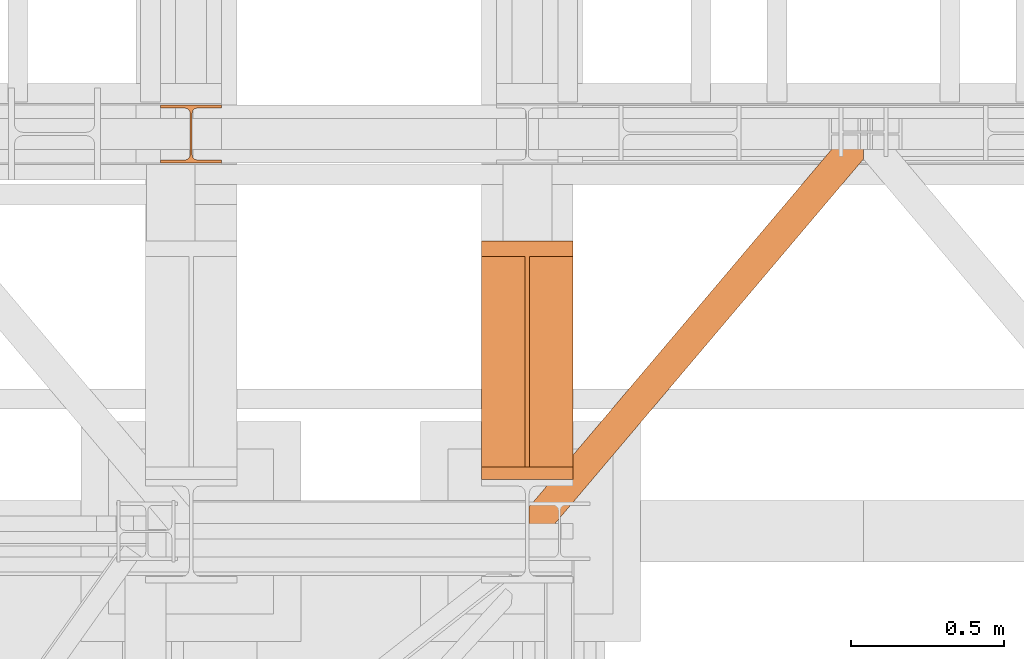
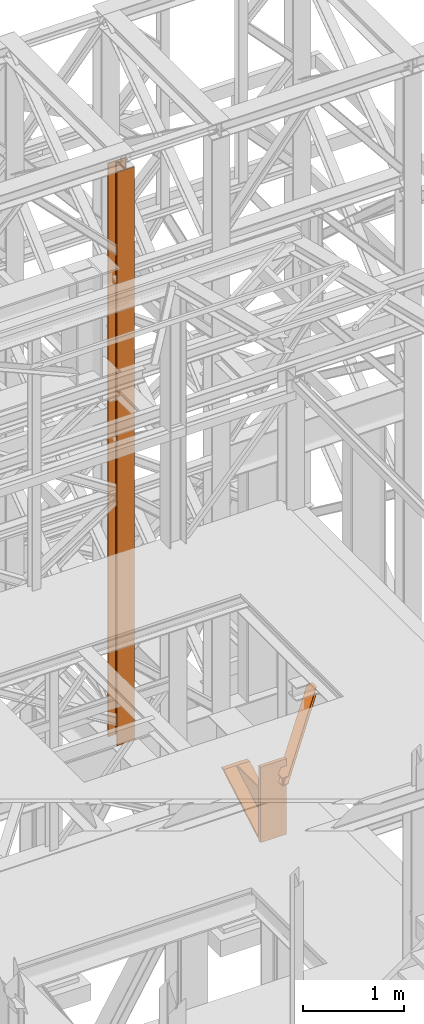
# One storey, part 151 of 208: 3 proxies.
"""IFC2X3 building model written with IfcOpenShell, lengths in millimetres."""

from ifc_helpers import new_model, entity, si_unit, converted_unit, frame, origin, origin_with_axes, place, context, subcontext, project, spatial, faceted_brep, element, save


model = new_model("IFC2X3")

# Units and contexts
model_context = context("Model", 3, precision=1e-05, world=origin())
plan_context = context("Plan", 3, precision=1e-05, world=origin())
body_context = subcontext(model_context, "Body", "Model", "MODEL_VIEW")
ifc_project = project(units=[si_unit("LENGTHUNIT", "METRE", prefix="MILLI"), converted_unit("PLANEANGLEUNIT", "DEGREE", entity("IfcPlaneAngleMeasure", 0.0174532925199433), si_unit("PLANEANGLEUNIT", "RADIAN"), dimensions=[0, 0, 0, 0, 0, 0, 0]), si_unit("AREAUNIT", "SQUARE_METRE"), si_unit("VOLUMEUNIT", "CUBIC_METRE")], contexts=[model_context, plan_context])

# Building, storey
building_placement = place(None, origin())
building = spatial("IfcBuilding", under=ifc_project, at=building_placement, CompositionType="COMPLEX")
storey_placement = place(building_placement, origin_with_axes())
storey = spatial("IfcBuildingStorey", under=building, at=storey_placement, Name="Geschoss", CompositionType="ELEMENT")

# Proxies
proxy_1_placement = place(storey_placement, frame((6443.254974489131, -17092.57439173937, 4367.230005364415), z_axis=(0.0, 0.0, 1.0), x_axis=(1.0, 0.0, 0.0)))
element("IfcBuildingElementProxy", 1, at=proxy_1_placement, inside=storey, context=body_context, shape_type="Brep", body=[
    faceted_brep([(0.01000000000021828, 40.0099999999984, 18.61000000000058), (300.0100000000002, 40.0099999999984, 18.61000000000058), (300.0100000000002, 779.8719999999976, 445.7700000000004), (0.01000000000021828, 779.8719999999976, 445.7700000000004), (0.01000000000021828, 779.8719999999976, 445.7700000000004), (300.0100000000002, 779.8719999999976, 445.7700000000004), (300.0100000000002, 729.8159999999989, 445.7710000000006), (157.5100000000002, 729.8159999999989, 445.7710000000006), (157.5100000000002, 40.0099999999984, 445.7700000000004), (142.5100000000002, 40.0099999999984, 445.7700000000004), (142.5100000000002, 729.8159999999989, 445.7710000000006), (0.01000000000021828, 729.8159999999971, 445.7710000000006), (0.01000000000021828, 729.8159999999971, 445.7710000000006), (142.5100000000002, 729.8159999999989, 445.7710000000006), (142.5100000000002, 40.0099999999984, 47.51000000000022), (0.01000000000021828, 40.0099999999984, 47.51000000000022), (157.5100000000002, 40.0099999999984, 47.51000000000022), (157.5100000000002, 729.8159999999989, 445.7710000000006), (300.0100000000002, 729.8159999999989, 445.7710000000006), (300.0100000000002, 40.0099999999984, 47.51000000000022), (0.01000000000021828, 40.0099999999984, 18.61000000000058), (0.01000000000021828, 779.8719999999976, 445.7700000000004), (0.01000000000021828, 729.8159999999971, 445.7710000000006), (0.01000000000021828, 40.0099999999984, 47.51000000000022), (0.01000000000021828, 40.0099999999984, 917.7700000000004), (0.01000000000021828, 0.00999999999839929, 917.7700000000004), (0.01000000000021828, 0.00999999999839929, 0.01000000000021828), (0.01000000000021828, 40.0099999999984, 0.01000000000021828), (300.0100000000002, 0.00999999999839929, 917.7700000000004), (300.0100000000002, 40.0099999999984, 917.7700000000004), (300.0100000000002, 40.0099999999984, 47.51000000000022), (300.0100000000002, 729.8159999999989, 445.7710000000006), (300.0100000000002, 779.8719999999976, 445.7700000000004), (300.0100000000002, 40.0099999999984, 18.61000000000058), (300.0100000000002, 40.0099999999984, 0.01000000000021828), (300.0100000000002, 0.00999999999839929, 0.01000000000021828), (300.0100000000002, 0.00999999999839929, 917.7700000000004), (0.01000000000021828, 0.00999999999839929, 917.7700000000004), (0.01000000000021828, 40.0099999999984, 917.7700000000004), (300.0100000000002, 40.0099999999984, 917.7700000000004), (300.0100000000002, 40.0099999999984, 917.7700000000004), (0.01000000000021828, 40.0099999999984, 917.7700000000004), (0.01000000000021828, 40.0099999999984, 47.51000000000022), (142.5100000000002, 40.0099999999984, 47.51000000000022), (142.5100000000002, 40.0099999999984, 445.7700000000004), (157.5100000000002, 40.0099999999984, 445.7700000000004), (157.5100000000002, 40.0099999999984, 47.51000000000022), (300.0100000000002, 40.0099999999984, 47.51000000000022), (300.0100000000002, 40.0099999999984, 18.61000000000058), (0.01000000000021828, 40.0099999999984, 18.61000000000058), (0.01000000000021828, 40.0099999999984, 0.01000000000021828), (300.0100000000002, 40.0099999999984, 0.01000000000021828), (300.0100000000002, 40.0099999999984, 0.01000000000021828), (0.01000000000021828, 40.0099999999984, 0.01000000000021828), (0.01000000000021828, 0.00999999999839929, 0.01000000000021828), (300.0100000000002, 0.00999999999839929, 0.01000000000021828), (300.0100000000002, 0.00999999999839929, 0.01000000000021828), (0.01000000000021828, 0.00999999999839929, 0.01000000000021828), (0.01000000000021828, 0.00999999999839929, 917.7700000000004), (300.0100000000002, 0.00999999999839929, 917.7700000000004), (142.5100000000002, 40.0099999999984, 47.51000000000022), (142.5100000000002, 729.8159999999989, 445.7710000000006), (142.5100000000002, 40.0099999999984, 445.7700000000004), (157.5100000000002, 40.0099999999984, 47.51000000000022), (157.5100000000002, 40.0099999999984, 445.7700000000004), (157.5100000000002, 729.8159999999989, 445.7710000000006)], [[[0, 1, 2, 3]], [[4, 5, 6, 7, 8, 9, 10, 11]], [[12, 13, 14, 15]], [[16, 17, 18, 19]], [[20, 21, 22, 23, 24, 25, 26, 27]], [[28, 29, 30, 31, 32, 33, 34, 35]], [[36, 37, 38, 39]], [[40, 41, 42, 43, 44, 45, 46, 47]], [[48, 49, 50, 51]], [[52, 53, 54, 55]], [[56, 57, 58, 59]], [[60, 61, 62]], [[63, 64, 65]]], orient=[[False], [False], [False], [False], [False], [False], [False], [False], [False], [False], [False], [False], [False]]),
])
proxy_2_placement = place(storey_placement, frame((6599.254968580832, -17257.87439359531, 5101.990016164881), z_axis=(0.0, 0.0, 1.0), x_axis=(1.0, 0.0, 0.0)))
element("IfcBuildingElementProxy", 2, at=proxy_2_placement, inside=storey, context=body_context, shape_type="Brep", body=[
    faceted_brep([(1028.512359102908, 1290.610003345228, 8.010001311302403), (0.01000000000021828, 75.10721531451418, 8.010001311303313), (0.01000000000021828, 75.10721531451418, 0.01000000000021828), (1028.512359102908, 1290.610003345228, 0.01000000000021828), (1028.512359102908, 1290.610003345228, 0.01000000000021828), (0.01000000000021828, 75.10721531451418, 0.01000000000021828), (0.01000000000021828, 0.00999999999839929, 0.01000000000021828), (67.46148411605282, 0.00999999999839929, 0.01000000000021828), (1094.009999947844, 1213.20370052848, 0.01000000000021828), (1094.009999947844, 1290.610003345228, 0.01000000000021828), (1094.009999947844, 1213.20370052848, 0.01000000000021828), (67.46148411605282, 0.00999999999839929, 0.01000000000021828), (67.46148411605282, 0.00999999999839929, 8.010001311302403), (1094.009999947846, 1213.203700528482, 8.010001311302403), (1094.009999947846, 1213.203700528482, 8.010001311302403), (67.46148411605282, 0.00999999999839929, 8.010001311302403), (20.95815950654287, 0.00999999999839929, 8.010001311302403), (1094.009999947845, 1268.162175066993, 8.010001311302403), (1094.009999947845, 1268.162175066993, 8.010001311302403), (20.95815950654287, 0.00999999999839929, 8.010001311302403), (12.82264470841801, 0.00999999999839929, 9.253033826351384), (1094.009999947845, 1277.776874373869, 9.253033826351384), (1094.009999947845, 1277.776874373869, 9.253033826351384), (12.82264470841801, 0.00999999999839929, 9.253033826351384), (6.86703880668756, 0.00999999999839929, 13.79946006298087), (1094.009999947845, 1284.815317712277, 13.79946006298087), (1094.009999947845, 1284.815317712277, 13.79946006298087), (6.86703880668756, 0.00999999999839929, 13.79946006298087), (5.23872549636144, 0.00999999999839929, 20.01000141560962), (1094.009999947844, 1286.739687988118, 20.01000141561053), (1094.009999947844, 1286.739687988118, 20.01000141561053), (5.23872549636144, 0.00999999999839929, 20.01000141560962), (5.23872549636144, 0.00999999999839929, 76.01000128150008), (1094.009999947845, 1286.739687988116, 76.01000128150008), (1094.009999947845, 1286.739687988116, 76.01000128150008), (5.23872549636144, 0.00999999999839929, 76.01000128150008), (6.86703880668847, 0.00999999999839929, 82.2205407714846), (1094.009999947845, 1284.815317712277, 82.2205407714846), (1094.009999947845, 1284.815317712277, 82.2205407714846), (6.86703880668847, 0.00999999999839929, 82.2205407714846), (12.82264470841892, 0.00999999999839929, 86.76696700811317), (1094.009999947845, 1277.776874373869, 86.76696700811408), (1094.009999947845, 1277.776874373869, 86.76696700811408), (12.82264470841892, 0.00999999999839929, 86.76696700811317), (20.95815950654469, 0.00999999999839929, 88.00999952316306), (1094.009999947845, 1268.162175066993, 88.00999952316306), (1094.009999947845, 1268.162175066993, 88.00999952316306), (20.95815950654469, 0.00999999999839929, 88.00999952316306), (67.46148411605373, 0.00999999999839929, 88.00999952316397), (1094.009999947845, 1213.20370052848, 88.00999952316306), (1094.009999947845, 1213.20370052848, 88.00999952316306), (67.46148411605373, 0.00999999999839929, 88.00999952316397), (67.46148411605373, 0.00999999999839929, 96.01000083446525), (1094.009999947847, 1213.203700528484, 96.01000083446525), (1094.009999947847, 1213.203700528484, 96.01000083446525), (67.46148411605373, 0.00999999999839929, 96.01000083446525), (0.01000000000021828, 0.00999999999839929, 96.01000083446525), (0.01000000000021828, 75.10721531451418, 96.01000083446525), (1028.512359102909, 1290.610003345228, 96.01000083446525), (1094.009999947846, 1290.610003345228, 96.01000083446525), (1028.512359102909, 1290.610003345228, 96.01000083446525), (0.01000000000021828, 75.10721531451418, 96.01000083446525), (0.01000000000021828, 75.10721531451418, 88.00999952316306), (1028.512359102909, 1290.610003345228, 88.00999952316306), (1028.512359102909, 1290.610003345228, 88.00999952316306), (0.01000000000021828, 75.10721531451418, 88.00999952316306), (0.01000000000021828, 20.14874077600325, 88.00999952316215), (1075.01568371242, 1290.610003345228, 88.00999952316306), (1075.01568371242, 1290.610003345228, 88.00999952316306), (0.01000000000021828, 20.14874077600325, 88.00999952316215), (0.01000000000021828, 10.53404146912726, 86.76696700811499), (1083.151198510545, 1290.610003345228, 86.76696700811408), (1083.151198510545, 1290.610003345228, 86.76696700811408), (0.01000000000021828, 10.53404146912726, 86.76696700811499), (0.01000000000021828, 3.495598130721191, 82.2205407714855), (1089.106804412275, 1290.610003345228, 82.2205407714846), (1089.106804412275, 1290.610003345228, 82.2205407714846), (0.01000000000021828, 3.495598130721191, 82.2205407714855), (0.01000000000021828, 1.571227854878089, 76.01000128150008), (1090.735117722602, 1290.610003345228, 76.01000128150008), (1090.735117722602, 1290.610003345228, 76.01000128150008), (0.01000000000021828, 1.571227854878089, 76.01000128150008), (0.01000000000021828, 1.571227854878089, 20.01000141561053), (1090.735117722601, 1290.610003345228, 20.01000141561053), (1090.735117722601, 1290.610003345228, 20.01000141561053), (0.01000000000021828, 1.571227854878089, 20.01000141561053), (0.01000000000021828, 3.495598130717553, 13.79946006298087), (1089.106804412275, 1290.610003345228, 13.79946006298087), (1089.106804412275, 1290.610003345228, 13.79946006298087), (0.01000000000021828, 3.495598130717553, 13.79946006298087), (0.01000000000021828, 10.53404146912726, 9.253033826351384), (1083.151198510544, 1290.610003345228, 9.253033826351384), (1083.151198510544, 1290.610003345228, 9.253033826351384), (0.01000000000021828, 10.53404146912726, 9.253033826351384), (0.01000000000021828, 20.14874077600325, 8.010001311302403), (1075.015683712418, 1290.610003345228, 8.010001311302403), (1075.015683712418, 1290.610003345228, 8.010001311302403), (0.01000000000021828, 20.14874077600325, 8.010001311302403), (0.01000000000021828, 75.10721531451418, 8.010001311303313), (1028.512359102908, 1290.610003345228, 8.010001311302403), (1094.009999947844, 1213.20370052848, 0.01000000000021828), (1094.009999947846, 1213.203700528482, 8.010001311302403), (1094.009999947845, 1268.162175066993, 8.010001311302403), (1094.009999947845, 1277.776874373869, 9.253033826351384), (1094.009999947845, 1284.815317712277, 13.79946006298087), (1094.009999947844, 1286.739687988118, 20.01000141561053), (1094.009999947845, 1286.739687988116, 76.01000128150008), (1094.009999947845, 1284.815317712277, 82.2205407714846), (1094.009999947845, 1277.776874373869, 86.76696700811408), (1094.009999947845, 1268.162175066993, 88.00999952316306), (1094.009999947845, 1213.20370052848, 88.00999952316306), (1094.009999947847, 1213.203700528484, 96.01000083446525), (1094.009999947846, 1290.610003345228, 96.01000083446525), (1094.009999947844, 1290.610003345228, 0.01000000000021828), (1094.009999947846, 1290.610003345228, 96.01000083446525), (1028.512359102909, 1290.610003345228, 96.01000083446525), (1028.512359102909, 1290.610003345228, 88.00999952316306), (1075.01568371242, 1290.610003345228, 88.00999952316306), (1083.151198510545, 1290.610003345228, 86.76696700811408), (1089.106804412275, 1290.610003345228, 82.2205407714846), (1090.735117722602, 1290.610003345228, 76.01000128150008), (1090.735117722601, 1290.610003345228, 20.01000141561053), (1089.106804412275, 1290.610003345228, 13.79946006298087), (1083.151198510544, 1290.610003345228, 9.253033826351384), (1075.015683712418, 1290.610003345228, 8.010001311302403), (1028.512359102908, 1290.610003345228, 8.010001311302403), (1028.512359102908, 1290.610003345228, 0.01000000000021828), (1094.009999947844, 1290.610003345228, 0.01000000000021828), (0.01000000000021828, 75.10721531451418, 0.01000000000021828), (0.01000000000021828, 75.10721531451418, 8.010001311303313), (0.01000000000021828, 20.14874077600325, 8.010001311302403), (0.01000000000021828, 10.53404146912726, 9.253033826351384), (0.01000000000021828, 3.495598130717553, 13.79946006298087), (0.01000000000021828, 1.571227854878089, 20.01000141561053), (0.01000000000021828, 1.571227854878089, 76.01000128150008), (0.01000000000021828, 3.495598130721191, 82.2205407714855), (0.01000000000021828, 10.53404146912726, 86.76696700811499), (0.01000000000021828, 20.14874077600325, 88.00999952316215), (0.01000000000021828, 75.10721531451418, 88.00999952316306), (0.01000000000021828, 75.10721531451418, 96.01000083446525), (0.01000000000021828, 0.00999999999839929, 96.01000083446525), (0.01000000000021828, 0.00999999999839929, 0.01000000000021828), (67.46148411605282, 0.00999999999839929, 0.01000000000021828), (0.01000000000021828, 0.00999999999839929, 0.01000000000021828), (0.01000000000021828, 0.00999999999839929, 96.01000083446525), (67.46148411605373, 0.00999999999839929, 96.01000083446525), (67.46148411605373, 0.00999999999839929, 88.00999952316397), (20.95815950654469, 0.00999999999839929, 88.00999952316306), (12.82264470841892, 0.00999999999839929, 86.76696700811317), (6.86703880668847, 0.00999999999839929, 82.2205407714846), (5.23872549636144, 0.00999999999839929, 76.01000128150008), (5.23872549636144, 0.00999999999839929, 20.01000141560962), (6.86703880668756, 0.00999999999839929, 13.79946006298087), (12.82264470841801, 0.00999999999839929, 9.253033826351384), (20.95815950654287, 0.00999999999839929, 8.010001311302403), (67.46148411605282, 0.00999999999839929, 8.010001311302403)], [[[0, 1, 2, 3]], [[4, 5, 6, 7, 8, 9]], [[10, 11, 12, 13]], [[14, 15, 16, 17]], [[18, 19, 20, 21]], [[22, 23, 24, 25]], [[26, 27, 28, 29]], [[30, 31, 32, 33]], [[34, 35, 36, 37]], [[38, 39, 40, 41]], [[42, 43, 44, 45]], [[46, 47, 48, 49]], [[50, 51, 52, 53]], [[54, 55, 56, 57, 58, 59]], [[60, 61, 62, 63]], [[64, 65, 66, 67]], [[68, 69, 70, 71]], [[72, 73, 74, 75]], [[76, 77, 78, 79]], [[80, 81, 82, 83]], [[84, 85, 86, 87]], [[88, 89, 90, 91]], [[92, 93, 94, 95]], [[96, 97, 98, 99]], [[100, 101, 102, 103, 104, 105, 106, 107, 108, 109, 110, 111, 112, 113]], [[114, 115, 116, 117, 118, 119, 120, 121, 122, 123, 124, 125, 126, 127]], [[128, 129, 130, 131, 132, 133, 134, 135, 136, 137, 138, 139, 140, 141]], [[142, 143, 144, 145, 146, 147, 148, 149, 150, 151, 152, 153, 154, 155]]], orient=[[False], [False], [False], [False], [False], [False], [False], [False], [False], [False], [False], [False], [False], [False], [False], [False], [False], [False], [False], [False], [False], [False], [False], [False], [False], [False], [False], [False]]),
])
proxy_3_placement = place(storey_placement, frame((5393.254967038551, -16057.57439657638, 5284.990005364419), z_axis=(0.0, 0.0, 1.0), x_axis=(1.0, 0.0, 0.0)))
element("IfcBuildingElementProxy", 3, at=proxy_3_placement, inside=storey, context=body_context, shape_type="Brep", body=[
    faceted_brep([(0.009999999999308784, 190.0100125169774, 6965.010053329391), (200.0100029802316, 190.0100125169774, 6965.010053329391), (200.0100029802316, 180.01001460314, 6965.010053329391), (121.260003576278, 180.0100071525594, 6965.010053329391), (111.9441915473335, 178.1454621052762, 6965.010053329391), (105.1245498640828, 171.3258190250417, 6965.010053329391), (103.2600015571707, 162.0100079274198, 6965.010053329391), (103.2600015571707, 28.00999713897909, 6965.010053329391), (105.1245498640828, 18.69418604135717, 6965.010053329391), (111.9441915473335, 11.87454296112264, 6965.010053329391), (121.260003576278, 10.00999791383947, 6965.010053329391), (200.0100029802316, 10.00999791383947, 6965.010053329391), (200.0100029802316, 0.01000000000203727, 6965.010053329391), (0.009999999999308784, 0.01000000000203727, 6965.010053329391), (0.009999999999308784, 10.00999791383947, 6965.010053329391), (78.75999940395286, 10.00999791383947, 6965.010053329391), (88.07581143289735, 11.87454296112264, 6965.010053329391), (94.89545311614802, 18.69418604135717, 6965.010053329391), (96.7600014230602, 28.00999713897909, 6965.010053329391), (96.7600014230602, 162.0100079274198, 6965.010053329391), (94.89545311614802, 171.3258190250417, 6965.010053329391), (88.07581143289735, 178.1454621052762, 6965.010053329391), (78.75999940395286, 180.0100071525594, 6965.010053329391), (0.009999999999308784, 180.01001460314, 6965.010053329391), (200.0100029802316, 190.0100125169774, 6965.010053329391), (0.009999999999308784, 190.0100125169774, 6965.010053329391), (0.01000000000021828, 190.0100125169756, 0.009999999999308784), (200.0100029802325, 190.0100125169756, 0.009999999999308784), (200.0100029802316, 180.01001460314, 6965.010053329391), (200.0100029802316, 190.0100125169774, 6965.010053329391), (200.0100029802325, 190.0100125169756, 0.009999999999308784), (200.0100029802325, 180.0100146031382, 0.009999999999308784), (121.260003576278, 180.0100071525594, 6965.010053329391), (200.0100029802316, 180.01001460314, 6965.010053329391), (200.0100029802325, 180.0100146031382, 0.009999999999308784), (121.2600035762789, 180.0100071525576, 0.009999999999308784), (111.9441915473335, 178.1454621052762, 6965.010053329391), (121.260003576278, 180.0100071525594, 6965.010053329391), (121.2600035762789, 180.0100071525576, 0.009999999999308784), (111.9441915473344, 178.1454621052744, 0.009999999999308784), (105.1245498640828, 171.3258190250417, 6965.010053329391), (111.9441915473335, 178.1454621052762, 6965.010053329391), (111.9441915473344, 178.1454621052744, 0.009999999999308784), (105.1245498640838, 171.3258190250399, 0.009999999999308784), (103.2600015571707, 162.0100079274198, 6965.010053329391), (105.1245498640828, 171.3258190250417, 6965.010053329391), (105.1245498640838, 171.3258190250399, 0.009999999999308784), (103.2600015571716, 162.010007927418, 0.009999999999308784), (103.2600015571707, 28.00999713897909, 6965.010053329391), (103.2600015571707, 162.0100079274198, 6965.010053329391), (103.2600015571716, 162.010007927418, 0.009999999999308784), (103.2600015571716, 28.00999713897727, 0.009999999999308784), (105.1245498640828, 18.69418604135717, 6965.010053329391), (103.2600015571707, 28.00999713897909, 6965.010053329391), (103.2600015571716, 28.00999713897727, 0.009999999999308784), (105.1245498640838, 18.69418604135535, 0.009999999999308784), (111.9441915473335, 11.87454296112264, 6965.010053329391), (105.1245498640828, 18.69418604135717, 6965.010053329391), (105.1245498640838, 18.69418604135535, 0.009999999999308784), (111.9441915473344, 11.87454296112082, 0.009999999999308784), (121.260003576278, 10.00999791383947, 6965.010053329391), (111.9441915473335, 11.87454296112264, 6965.010053329391), (111.9441915473344, 11.87454296112082, 0.009999999999308784), (121.2600035762789, 10.00999791383765, 0.009999999999308784), (200.0100029802316, 10.00999791383947, 6965.010053329391), (121.260003576278, 10.00999791383947, 6965.010053329391), (121.2600035762789, 10.00999791383765, 0.009999999999308784), (200.0100029802325, 10.00999791383765, 0.009999999999308784), (200.0100029802316, 0.01000000000203727, 6965.010053329391), (200.0100029802316, 10.00999791383947, 6965.010053329391), (200.0100029802325, 10.00999791383765, 0.009999999999308784), (200.0100029802325, 0.01000000000021828, 0.009999999999308784), (0.009999999999308784, 0.01000000000203727, 6965.010053329391), (200.0100029802316, 0.01000000000203727, 6965.010053329391), (200.0100029802325, 0.01000000000021828, 0.009999999999308784), (0.01000000000021828, 0.01000000000021828, 0.009999999999308784), (0.009999999999308784, 10.00999791383947, 6965.010053329391), (0.009999999999308784, 0.01000000000203727, 6965.010053329391), (0.01000000000021828, 0.01000000000021828, 0.009999999999308784), (0.01000000000021828, 10.00999791383765, 0.009999999999308784), (78.75999940395286, 10.00999791383947, 6965.010053329391), (0.009999999999308784, 10.00999791383947, 6965.010053329391), (0.01000000000021828, 10.00999791383765, 0.009999999999308784), (78.75999940395377, 10.00999791383765, 0.009999999999308784), (88.07581143289735, 11.87454296112264, 6965.010053329391), (78.75999940395286, 10.00999791383947, 6965.010053329391), (78.75999940395377, 10.00999791383765, 0.009999999999308784), (88.07581143289826, 11.87454296112082, 0.009999999999308784), (94.89545311614802, 18.69418604135717, 6965.010053329391), (88.07581143289735, 11.87454296112264, 6965.010053329391), (88.07581143289826, 11.87454296112082, 0.009999999999308784), (94.89545311614893, 18.69418604135535, 0.009999999999308784), (96.7600014230602, 28.00999713897909, 6965.010053329391), (94.89545311614802, 18.69418604135717, 6965.010053329391), (94.89545311614893, 18.69418604135535, 0.009999999999308784), (96.76000142306111, 28.00999713897727, 0.009999999999308784), (96.7600014230602, 162.0100079274198, 6965.010053329391), (96.7600014230602, 28.00999713897909, 6965.010053329391), (96.76000142306111, 28.00999713897727, 0.009999999999308784), (96.76000142306111, 162.010007927418, 0.009999999999308784), (94.89545311614802, 171.3258190250417, 6965.010053329391), (96.7600014230602, 162.0100079274198, 6965.010053329391), (96.76000142306111, 162.010007927418, 0.009999999999308784), (94.89545311614893, 171.3258190250399, 0.009999999999308784), (88.07581143289735, 178.1454621052762, 6965.010053329391), (94.89545311614802, 171.3258190250417, 6965.010053329391), (94.89545311614893, 171.3258190250399, 0.009999999999308784), (88.07581143289826, 178.1454621052744, 0.009999999999308784), (78.75999940395286, 180.0100071525594, 6965.010053329391), (88.07581143289735, 178.1454621052762, 6965.010053329391), (88.07581143289826, 178.1454621052744, 0.009999999999308784), (78.75999940395377, 180.0100071525576, 0.009999999999308784), (0.009999999999308784, 180.01001460314, 6965.010053329391), (78.75999940395286, 180.0100071525594, 6965.010053329391), (78.75999940395377, 180.0100071525576, 0.009999999999308784), (0.01000000000021828, 180.0100146031382, 0.009999999999308784), (0.009999999999308784, 190.0100125169774, 6965.010053329391), (0.009999999999308784, 180.01001460314, 6965.010053329391), (0.01000000000021828, 180.0100146031382, 0.009999999999308784), (0.01000000000021828, 190.0100125169756, 0.009999999999308784), (0.01000000000021828, 190.0100125169756, 0.009999999999308784), (0.01000000000021828, 180.0100146031382, 0.009999999999308784), (78.75999940395377, 180.0100071525576, 0.009999999999308784), (88.07581143289826, 178.1454621052744, 0.009999999999308784), (94.89545311614893, 171.3258190250399, 0.009999999999308784), (96.76000142306111, 162.010007927418, 0.009999999999308784), (96.76000142306111, 28.00999713897727, 0.009999999999308784), (94.89545311614893, 18.69418604135535, 0.009999999999308784), (88.07581143289826, 11.87454296112082, 0.009999999999308784), (78.75999940395377, 10.00999791383765, 0.009999999999308784), (0.01000000000021828, 10.00999791383765, 0.009999999999308784), (0.01000000000021828, 0.01000000000021828, 0.009999999999308784), (200.0100029802325, 0.01000000000021828, 0.009999999999308784), (200.0100029802325, 10.00999791383765, 0.009999999999308784), (121.2600035762789, 10.00999791383765, 0.009999999999308784), (111.9441915473344, 11.87454296112082, 0.009999999999308784), (105.1245498640838, 18.69418604135535, 0.009999999999308784), (103.2600015571716, 28.00999713897727, 0.009999999999308784), (103.2600015571716, 162.010007927418, 0.009999999999308784), (105.1245498640838, 171.3258190250399, 0.009999999999308784), (111.9441915473344, 178.1454621052744, 0.009999999999308784), (121.2600035762789, 180.0100071525576, 0.009999999999308784), (200.0100029802325, 180.0100146031382, 0.009999999999308784), (200.0100029802325, 190.0100125169756, 0.009999999999308784)], [[[0, 1, 2, 3, 4, 5, 6, 7, 8, 9, 10, 11, 12, 13, 14, 15, 16, 17, 18, 19, 20, 21, 22, 23]], [[24, 25, 26, 27]], [[28, 29, 30, 31]], [[32, 33, 34, 35]], [[36, 37, 38, 39]], [[40, 41, 42, 43]], [[44, 45, 46, 47]], [[48, 49, 50, 51]], [[52, 53, 54, 55]], [[56, 57, 58, 59]], [[60, 61, 62, 63]], [[64, 65, 66, 67]], [[68, 69, 70, 71]], [[72, 73, 74, 75]], [[76, 77, 78, 79]], [[80, 81, 82, 83]], [[84, 85, 86, 87]], [[88, 89, 90, 91]], [[92, 93, 94, 95]], [[96, 97, 98, 99]], [[100, 101, 102, 103]], [[104, 105, 106, 107]], [[108, 109, 110, 111]], [[112, 113, 114, 115]], [[116, 117, 118, 119]], [[120, 121, 122, 123, 124, 125, 126, 127, 128, 129, 130, 131, 132, 133, 134, 135, 136, 137, 138, 139, 140, 141, 142, 143]]], orient=[[False], [False], [False], [False], [False], [False], [False], [False], [False], [False], [False], [False], [False], [False], [False], [False], [False], [False], [False], [False], [False], [False], [False], [False], [False], [False]]),
])

save(model, "model.ifc")
